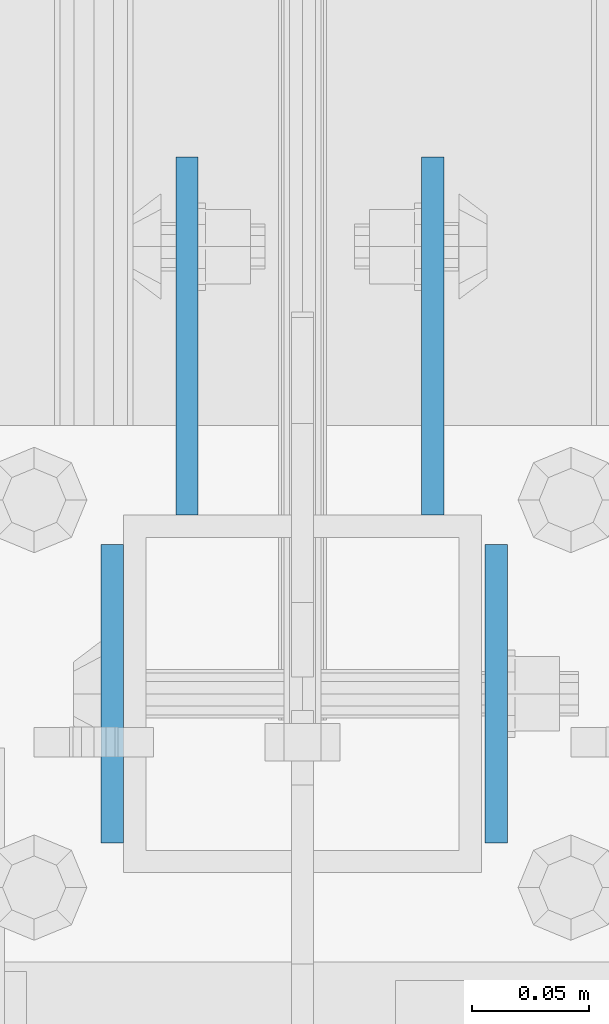
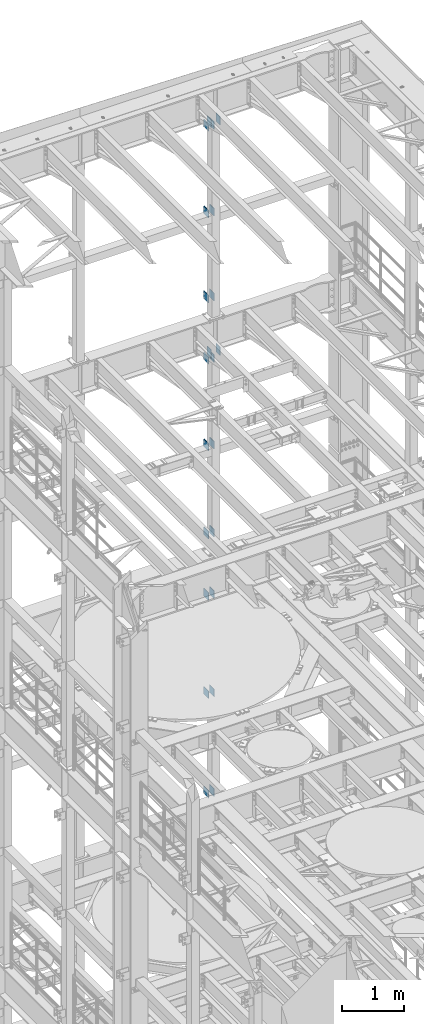
# One storey, part 1327 of 1876: 22 beams, 5 elements without a shape of their own.
"""IFC2X3 building model written with IfcOpenShell, lengths in millimetres."""

from ifc_helpers import new_model, si_unit, frame, origin_with_axes, place, context, subcontext, project, spatial, faceted_brep, material, type_object, element, aggregate, save


model = new_model("IFC2X3")

# Units and contexts
model_context = context("Model", 3, precision=1e-05, world=origin_with_axes())
body_context = subcontext(model_context, "Body", "Model", "MODEL_VIEW")
ifc_project = project(units=[si_unit("LENGTHUNIT", "METRE", prefix="MILLI"), si_unit("AREAUNIT", "SQUARE_METRE"), si_unit("VOLUMEUNIT", "CUBIC_METRE"), si_unit("MASSUNIT", "GRAM", prefix="KILO"), si_unit("TIMEUNIT", "SECOND"), si_unit("PLANEANGLEUNIT", "RADIAN"), si_unit("SOLIDANGLEUNIT", "STERADIAN"), si_unit("THERMODYNAMICTEMPERATUREUNIT", "DEGREE_CELSIUS"), si_unit("LUMINOUSINTENSITYUNIT", "LUMEN")], contexts=[model_context])

# Site, building, storey
site_placement = place(None, origin_with_axes())
site = spatial("IfcSite", under=ifc_project, at=site_placement, CompositionType="ELEMENT")
building_placement = place(site_placement, origin_with_axes())
building = spatial("IfcBuilding", under=site, at=building_placement, Name="Undefined", CompositionType="ELEMENT")
storey_placement = place(building_placement, origin_with_axes())
storey = spatial("IfcBuildingStorey", under=building, at=storey_placement, Name="Undefined", CompositionType="ELEMENT", Elevation=0.0)

# Assembly, beams
assembly_1_placement = place(storey_placement, origin_with_axes())
assembly_1 = element("IfcElementAssembly", 1, at=assembly_1_placement, inside=storey, Name="FRAME", AssemblyPlace="NOTDEFINED", PredefinedType="RIGID_FRAME")
ifc_material = material(Name="STEEL/A36")
beam_type_1 = type_object("IfcBeamType", PredefinedType="NOTDEFINED")
beam_1_placement = place(assembly_1_placement, frame((5030.7762944527, 13792.2, 21678.9), z_axis=(0.0, 0.0, -1.0), x_axis=(0.0, 1.0, 0.0)))
beam_1 = element("IfcBeam", 2, at=beam_1_placement, type_object=beam_type_1, material=ifc_material, Name="PLATE", context=body_context, shape_type="Brep", body=[
    faceted_brep([(0.0, 4.76249999999982, -76.1999999999998), (3.63797880709171e-12, 4.76249999999982, 76.1999969482422), (152.399993896484, 4.76250000000073, 76.1999969482422), (152.4, 4.76249999999982, -76.1999999999998), (3.63797880709171e-12, -4.76249999999982, 76.1999969482422), (152.399993896484, -4.76250000000073, 76.1999969482422), (0.0, -4.76249999999982, -76.1999999999998), (152.4, -4.76249999999982, -76.1999999999998)], [[[0, 1, 2, 3]], [[4, 5, 2, 1]], [[4, 6, 7, 5]], [[6, 0, 3, 7]], [[5, 7, 3, 2]], [[6, 4, 1, 0]]]),
])
beam_2_placement = place(assembly_1_placement, frame((5135.5512944527, 13792.2, 21678.9), z_axis=(0.0, 0.0, -1.0), x_axis=(0.0, 1.0, 0.0)))
beam_2 = element("IfcBeam", 3, at=beam_2_placement, type_object=beam_type_1, material=ifc_material, Name="PLATE", context=body_context, shape_type="Brep", body=[
    faceted_brep([(0.0, 4.76249999999982, -76.1999999999998), (3.63797880709171e-12, 4.76249999999982, 76.1999969482422), (152.399993896484, 4.76250000000073, 76.1999969482422), (152.4, 4.76249999999982, -76.1999999999998), (3.63797880709171e-12, -4.76249999999982, 76.1999969482422), (152.399993896484, -4.76250000000073, 76.1999969482422), (0.0, -4.76249999999982, -76.1999999999998), (152.4, -4.76249999999982, -76.1999999999998)], [[[0, 1, 2, 3]], [[4, 5, 2, 1]], [[4, 6, 7, 5]], [[6, 0, 3, 7]], [[5, 7, 3, 2]], [[6, 4, 1, 0]]]),
])
beam_3_placement = place(assembly_1_placement, frame((5030.7762944527, 13792.2, 19958.05), z_axis=(0.0, 0.0, -1.0), x_axis=(0.0, 1.0, 0.0)))
beam_3 = element("IfcBeam", 4, at=beam_3_placement, type_object=beam_type_1, material=ifc_material, Name="PLATE", context=body_context, shape_type="Brep", body=[
    faceted_brep([(0.0, 4.76249999999982, -76.1999999999998), (3.63797880709171e-12, 4.76249999999982, 76.1999969482422), (152.399993896484, 4.76250000000073, 76.1999969482422), (152.4, 4.76249999999982, -76.1999999999998), (3.63797880709171e-12, -4.76249999999982, 76.1999969482422), (152.399993896484, -4.76250000000073, 76.1999969482422), (0.0, -4.76249999999982, -76.1999999999998), (152.4, -4.76249999999982, -76.1999999999998)], [[[0, 1, 2, 3]], [[4, 5, 2, 1]], [[4, 6, 7, 5]], [[6, 0, 3, 7]], [[5, 7, 3, 2]], [[6, 4, 1, 0]]]),
])
beam_4_placement = place(assembly_1_placement, frame((5135.5512944527, 13792.2, 19958.05), z_axis=(0.0, 0.0, -1.0), x_axis=(0.0, 1.0, 0.0)))
beam_4 = element("IfcBeam", 5, at=beam_4_placement, type_object=beam_type_1, material=ifc_material, Name="PLATE", context=body_context, shape_type="Brep", body=[
    faceted_brep([(0.0, 4.76249999999982, -76.1999999999998), (3.63797880709171e-12, 4.76249999999982, 76.1999969482422), (152.399993896484, 4.76250000000073, 76.1999969482422), (152.4, 4.76249999999982, -76.1999999999998), (3.63797880709171e-12, -4.76249999999982, 76.1999969482422), (152.399993896484, -4.76250000000073, 76.1999969482422), (0.0, -4.76249999999982, -76.1999999999998), (152.4, -4.76249999999982, -76.1999999999998)], [[[0, 1, 2, 3]], [[4, 5, 2, 1]], [[4, 6, 7, 5]], [[6, 0, 3, 7]], [[5, 7, 3, 2]], [[6, 4, 1, 0]]]),
])
beam_5_placement = place(assembly_1_placement, frame((5030.7762944527, 13792.2, 18275.3), z_axis=(0.0, 0.0, -1.0), x_axis=(0.0, 1.0, 0.0)))
beam_5 = element("IfcBeam", 6, at=beam_5_placement, type_object=beam_type_1, material=ifc_material, Name="PLATE", context=body_context, shape_type="Brep", body=[
    faceted_brep([(0.0, 4.76249999999982, -76.1999999999998), (3.63797880709171e-12, 4.76249999999982, 76.1999969482422), (152.399993896484, 4.76250000000073, 76.1999969482422), (152.4, 4.76249999999982, -76.1999999999998), (3.63797880709171e-12, -4.76249999999982, 76.1999969482422), (152.399993896484, -4.76250000000073, 76.1999969482422), (0.0, -4.76249999999982, -76.1999999999998), (152.4, -4.76249999999982, -76.1999999999998)], [[[0, 1, 2, 3]], [[4, 5, 2, 1]], [[4, 6, 7, 5]], [[6, 0, 3, 7]], [[5, 7, 3, 2]], [[6, 4, 1, 0]]]),
])
beam_6_placement = place(assembly_1_placement, frame((5135.5512944527, 13792.2, 18275.3), z_axis=(0.0, 0.0, -1.0), x_axis=(0.0, 1.0, 0.0)))
beam_6 = element("IfcBeam", 7, at=beam_6_placement, type_object=beam_type_1, material=ifc_material, Name="PLATE", context=body_context, shape_type="Brep", body=[
    faceted_brep([(0.0, 4.76249999999982, -76.1999999999998), (3.63797880709171e-12, 4.76249999999982, 76.1999969482422), (152.399993896484, 4.76250000000073, 76.1999969482422), (152.4, 4.76249999999982, -76.1999999999998), (3.63797880709171e-12, -4.76249999999982, 76.1999969482422), (152.399993896484, -4.76250000000073, 76.1999969482422), (0.0, -4.76249999999982, -76.1999999999998), (152.4, -4.76249999999982, -76.1999999999998)], [[[0, 1, 2, 3]], [[4, 5, 2, 1]], [[4, 6, 7, 5]], [[6, 0, 3, 7]], [[5, 7, 3, 2]], [[6, 4, 1, 0]]]),
])
aggregate(assembly_1, [beam_1, beam_2, beam_3, beam_4, beam_5, beam_6])

assembly_2_placement = place(storey_placement, origin_with_axes())
assembly_2 = element("IfcElementAssembly", 8, at=assembly_2_placement, inside=storey, Name="FRAME", AssemblyPlace="NOTDEFINED", PredefinedType="RIGID_FRAME")
beam_7_placement = place(assembly_2_placement, frame((5030.7762944527, 13792.2, 17056.1), z_axis=(0.0, 0.0, -1.0), x_axis=(0.0, 1.0, 0.0)))
beam_7 = element("IfcBeam", 9, at=beam_7_placement, type_object=beam_type_1, material=ifc_material, Name="PLATE", context=body_context, shape_type="Brep", body=[
    faceted_brep([(0.0, 4.76249999999982, -76.1999999999998), (3.63797880709171e-12, 4.76249999999982, 76.1999969482422), (152.399993896484, 4.76250000000073, 76.1999969482422), (152.4, 4.76249999999982, -76.1999999999998), (3.63797880709171e-12, -4.76249999999982, 76.1999969482422), (152.399993896484, -4.76250000000073, 76.1999969482422), (0.0, -4.76249999999982, -76.1999999999998), (152.4, -4.76249999999982, -76.1999999999998)], [[[0, 1, 2, 3]], [[4, 5, 2, 1]], [[4, 6, 7, 5]], [[6, 0, 3, 7]], [[5, 7, 3, 2]], [[6, 4, 1, 0]]]),
])
beam_8_placement = place(assembly_2_placement, frame((5135.5512944527, 13792.2, 17056.1), z_axis=(0.0, 0.0, -1.0), x_axis=(0.0, 1.0, 0.0)))
beam_8 = element("IfcBeam", 10, at=beam_8_placement, type_object=beam_type_1, material=ifc_material, Name="PLATE", context=body_context, shape_type="Brep", body=[
    faceted_brep([(0.0, 4.76249999999982, -76.1999999999998), (3.63797880709171e-12, 4.76249999999982, 76.1999969482422), (152.399993896484, 4.76250000000073, 76.1999969482422), (152.4, 4.76249999999982, -76.1999999999998), (3.63797880709171e-12, -4.76249999999982, 76.1999969482422), (152.399993896484, -4.76250000000073, 76.1999969482422), (0.0, -4.76249999999982, -76.1999999999998), (152.4, -4.76249999999982, -76.1999999999998)], [[[0, 1, 2, 3]], [[4, 5, 2, 1]], [[4, 6, 7, 5]], [[6, 0, 3, 7]], [[5, 7, 3, 2]], [[6, 4, 1, 0]]]),
])
beam_9_placement = place(assembly_2_placement, frame((5030.7762944527, 13792.2, 15335.25), z_axis=(0.0, 0.0, -1.0), x_axis=(0.0, 1.0, 0.0)))
beam_9 = element("IfcBeam", 11, at=beam_9_placement, type_object=beam_type_1, material=ifc_material, Name="PLATE", context=body_context, shape_type="Brep", body=[
    faceted_brep([(0.0, 4.76249999999982, -76.1999999999998), (3.63797880709171e-12, 4.76249999999982, 76.1999969482422), (152.399993896484, 4.76250000000073, 76.1999969482422), (152.4, 4.76249999999982, -76.1999999999998), (3.63797880709171e-12, -4.76249999999982, 76.1999969482422), (152.399993896484, -4.76250000000073, 76.1999969482422), (0.0, -4.76249999999982, -76.1999999999998), (152.4, -4.76249999999982, -76.1999999999998)], [[[0, 1, 2, 3]], [[4, 5, 2, 1]], [[4, 6, 7, 5]], [[6, 0, 3, 7]], [[5, 7, 3, 2]], [[6, 4, 1, 0]]]),
])
beam_10_placement = place(assembly_2_placement, frame((5135.5512944527, 13792.2, 15335.25), z_axis=(0.0, 0.0, -1.0), x_axis=(0.0, 1.0, 0.0)))
beam_10 = element("IfcBeam", 12, at=beam_10_placement, type_object=beam_type_1, material=ifc_material, Name="PLATE", context=body_context, shape_type="Brep", body=[
    faceted_brep([(0.0, 4.76249999999982, -76.1999999999998), (3.63797880709171e-12, 4.76249999999982, 76.1999969482422), (152.399993896484, 4.76250000000073, 76.1999969482422), (152.4, 4.76249999999982, -76.1999999999998), (3.63797880709171e-12, -4.76249999999982, 76.1999969482422), (152.399993896484, -4.76250000000073, 76.1999969482422), (0.0, -4.76249999999982, -76.1999999999998), (152.4, -4.76249999999982, -76.1999999999998)], [[[0, 1, 2, 3]], [[4, 5, 2, 1]], [[4, 6, 7, 5]], [[6, 0, 3, 7]], [[5, 7, 3, 2]], [[6, 4, 1, 0]]]),
])
beam_11_placement = place(assembly_2_placement, frame((5030.7762944527, 13792.2, 13589.0), z_axis=(0.0, 0.0, -1.0), x_axis=(0.0, 1.0, 0.0)))
beam_11 = element("IfcBeam", 13, at=beam_11_placement, type_object=beam_type_1, material=ifc_material, Name="PLATE", context=body_context, shape_type="Brep", body=[
    faceted_brep([(0.0, 4.76249999999982, -76.1999999999998), (3.63797880709171e-12, 4.76249999999982, 76.1999969482422), (152.399993896484, 4.76250000000073, 76.1999969482422), (152.4, 4.76249999999982, -76.1999999999998), (3.63797880709171e-12, -4.76249999999982, 76.1999969482422), (152.399993896484, -4.76250000000073, 76.1999969482422), (0.0, -4.76249999999982, -76.1999999999998), (152.4, -4.76249999999982, -76.1999999999998)], [[[0, 1, 2, 3]], [[4, 5, 2, 1]], [[4, 6, 7, 5]], [[6, 0, 3, 7]], [[5, 7, 3, 2]], [[6, 4, 1, 0]]]),
])
beam_12_placement = place(assembly_2_placement, frame((5135.5512944527, 13792.2, 13589.0), z_axis=(0.0, 0.0, -1.0), x_axis=(0.0, 1.0, 0.0)))
beam_12 = element("IfcBeam", 14, at=beam_12_placement, type_object=beam_type_1, material=ifc_material, Name="PLATE", context=body_context, shape_type="Brep", body=[
    faceted_brep([(0.0, 4.76249999999982, -76.1999999999998), (3.63797880709171e-12, 4.76249999999982, 76.1999969482422), (152.399993896484, 4.76250000000073, 76.1999969482422), (152.4, 4.76249999999982, -76.1999999999998), (3.63797880709171e-12, -4.76249999999982, 76.1999969482422), (152.399993896484, -4.76250000000073, 76.1999969482422), (0.0, -4.76249999999982, -76.1999999999998), (152.4, -4.76249999999982, -76.1999999999998)], [[[0, 1, 2, 3]], [[4, 5, 2, 1]], [[4, 6, 7, 5]], [[6, 0, 3, 7]], [[5, 7, 3, 2]], [[6, 4, 1, 0]]]),
])
aggregate(assembly_2, [beam_7, beam_8, beam_9, beam_10, beam_11, beam_12])

assembly_3_placement = place(storey_placement, origin_with_axes())
assembly_3 = element("IfcElementAssembly", 15, at=assembly_3_placement, inside=storey, Name="FRAME", AssemblyPlace="NOTDEFINED", PredefinedType="RIGID_FRAME")
beam_13_placement = place(assembly_3_placement, frame((5030.7762944527, 13792.2, 12369.8), z_axis=(0.0, 0.0, -1.0), x_axis=(0.0, 1.0, 0.0)))
beam_13 = element("IfcBeam", 16, at=beam_13_placement, type_object=beam_type_1, material=ifc_material, Name="PLATE", context=body_context, shape_type="Brep", body=[
    faceted_brep([(0.0, 4.76249999999982, -76.1999999999998), (3.63797880709171e-12, 4.76249999999982, 76.1999969482422), (152.399993896484, 4.76250000000073, 76.1999969482422), (152.4, 4.76249999999982, -76.1999999999998), (3.63797880709171e-12, -4.76249999999982, 76.1999969482422), (152.399993896484, -4.76250000000073, 76.1999969482422), (0.0, -4.76249999999982, -76.1999999999998), (152.4, -4.76249999999982, -76.1999999999998)], [[[0, 1, 2, 3]], [[4, 5, 2, 1]], [[4, 6, 7, 5]], [[6, 0, 3, 7]], [[5, 7, 3, 2]], [[6, 4, 1, 0]]]),
])
beam_14_placement = place(assembly_3_placement, frame((5135.5512944527, 13792.2, 12369.8), z_axis=(0.0, 0.0, -1.0), x_axis=(0.0, 1.0, 0.0)))
beam_14 = element("IfcBeam", 17, at=beam_14_placement, type_object=beam_type_1, material=ifc_material, Name="PLATE", context=body_context, shape_type="Brep", body=[
    faceted_brep([(0.0, 4.76249999999982, -76.1999999999998), (3.63797880709171e-12, 4.76249999999982, 76.1999969482422), (152.399993896484, 4.76250000000073, 76.1999969482422), (152.4, 4.76249999999982, -76.1999999999998), (3.63797880709171e-12, -4.76249999999982, 76.1999969482422), (152.399993896484, -4.76250000000073, 76.1999969482422), (0.0, -4.76249999999982, -76.1999999999998), (152.4, -4.76249999999982, -76.1999999999998)], [[[0, 1, 2, 3]], [[4, 5, 2, 1]], [[4, 6, 7, 5]], [[6, 0, 3, 7]], [[5, 7, 3, 2]], [[6, 4, 1, 0]]]),
])
beam_15_placement = place(assembly_3_placement, frame((5030.7762944527, 13792.2, 10420.35), z_axis=(0.0, 0.0, -1.0), x_axis=(0.0, 1.0, 0.0)))
beam_15 = element("IfcBeam", 18, at=beam_15_placement, type_object=beam_type_1, material=ifc_material, Name="PLATE", context=body_context, shape_type="Brep", body=[
    faceted_brep([(0.0, 4.76249999999982, -76.1999999999998), (3.63797880709171e-12, 4.76249999999982, 76.1999969482422), (152.399993896484, 4.76250000000073, 76.1999969482422), (152.4, 4.76249999999982, -76.1999999999998), (3.63797880709171e-12, -4.76249999999982, 76.1999969482422), (152.399993896484, -4.76250000000073, 76.1999969482422), (0.0, -4.76249999999982, -76.1999999999998), (152.4, -4.76249999999982, -76.1999999999998)], [[[0, 1, 2, 3]], [[4, 5, 2, 1]], [[4, 6, 7, 5]], [[6, 0, 3, 7]], [[5, 7, 3, 2]], [[6, 4, 1, 0]]]),
])
beam_16_placement = place(assembly_3_placement, frame((5135.5512944527, 13792.2, 10420.35), z_axis=(0.0, 0.0, -1.0), x_axis=(0.0, 1.0, 0.0)))
beam_16 = element("IfcBeam", 19, at=beam_16_placement, type_object=beam_type_1, material=ifc_material, Name="PLATE", context=body_context, shape_type="Brep", body=[
    faceted_brep([(0.0, 4.76249999999982, -76.1999999999998), (3.63797880709171e-12, 4.76249999999982, 76.1999969482422), (152.399993896484, 4.76250000000073, 76.1999969482422), (152.4, 4.76249999999982, -76.1999999999998), (3.63797880709171e-12, -4.76249999999982, 76.1999969482422), (152.399993896484, -4.76250000000073, 76.1999969482422), (0.0, -4.76249999999982, -76.1999999999998), (152.4, -4.76249999999982, -76.1999999999998)], [[[0, 1, 2, 3]], [[4, 5, 2, 1]], [[4, 6, 7, 5]], [[6, 0, 3, 7]], [[5, 7, 3, 2]], [[6, 4, 1, 0]]]),
])
beam_17_placement = place(assembly_3_placement, frame((5030.7762944527, 13792.2, 8445.5), z_axis=(0.0, 0.0, -1.0), x_axis=(0.0, 1.0, 0.0)))
beam_17 = element("IfcBeam", 20, at=beam_17_placement, type_object=beam_type_1, material=ifc_material, Name="PLATE", context=body_context, shape_type="Brep", body=[
    faceted_brep([(0.0, 4.76249999999982, -76.1999999999998), (3.63797880709171e-12, 4.76249999999982, 76.1999969482422), (152.399993896484, 4.76250000000073, 76.1999969482422), (152.4, 4.76249999999982, -76.1999999999998), (3.63797880709171e-12, -4.76249999999982, 76.1999969482422), (152.399993896484, -4.76250000000073, 76.1999969482422), (0.0, -4.76249999999982, -76.1999999999998), (152.4, -4.76249999999982, -76.1999999999998)], [[[0, 1, 2, 3]], [[4, 5, 2, 1]], [[4, 6, 7, 5]], [[6, 0, 3, 7]], [[5, 7, 3, 2]], [[6, 4, 1, 0]]]),
])
beam_18_placement = place(assembly_3_placement, frame((5135.5512944527, 13792.2, 8445.5), z_axis=(0.0, 0.0, -1.0), x_axis=(0.0, 1.0, 0.0)))
beam_18 = element("IfcBeam", 21, at=beam_18_placement, type_object=beam_type_1, material=ifc_material, Name="PLATE", context=body_context, shape_type="Brep", body=[
    faceted_brep([(0.0, 4.76249999999982, -76.1999999999998), (3.63797880709171e-12, 4.76249999999982, 76.1999969482422), (152.399993896484, 4.76250000000073, 76.1999969482422), (152.4, 4.76249999999982, -76.1999999999998), (3.63797880709171e-12, -4.76249999999982, 76.1999969482422), (152.399993896484, -4.76250000000073, 76.1999969482422), (0.0, -4.76249999999982, -76.1999999999998), (152.4, -4.76249999999982, -76.1999999999998)], [[[0, 1, 2, 3]], [[4, 5, 2, 1]], [[4, 6, 7, 5]], [[6, 0, 3, 7]], [[5, 7, 3, 2]], [[6, 4, 1, 0]]]),
])
aggregate(assembly_3, [beam_13, beam_14, beam_15, beam_16, beam_17, beam_18])

assembly_4_placement = place(storey_placement, origin_with_axes())
assembly_4 = element("IfcElementAssembly", 22, at=assembly_4_placement, inside=storey, Name="BEAM", AssemblyPlace="NOTDEFINED", PredefinedType="RIGID_FRAME")
beam_type_2 = type_object("IfcBeamType", PredefinedType="NOTDEFINED")
beam_19_placement = place(assembly_4_placement, frame((5162.55, 13779.5, 17278.35), z_axis=(0.0, 0.0, -1.0), x_axis=(0.0, -1.0, 0.0)))
beam_19 = element("IfcBeam", 23, at=beam_19_placement, type_object=beam_type_2, material=ifc_material, Name="PLATE", context=body_context, shape_type="Brep", body=[
    faceted_brep([(0.0, 4.76249999999982, -82.5499999999993), (0.0, 4.76249999999982, 82.5499999999993), (127.0, 4.76249999999982, 82.5499999999993), (127.0, 4.76249999999982, -82.5499999999993), (0.0, -4.76249999999982, 82.5499999999993), (127.0, -4.76249999999982, 82.5499999999993), (0.0, -4.76249999999982, -82.5499999999993), (127.0, -4.76249999999982, -82.5499999999993)], [[[0, 1, 2, 3]], [[1, 4, 5, 2]], [[4, 6, 7, 5]], [[6, 0, 3, 7]], [[5, 7, 3, 2]], [[6, 4, 1, 0]]]),
])
beam_20_placement = place(assembly_4_placement, frame((4999.0375, 13779.5, 17278.35), z_axis=(0.0, 0.0, -1.0), x_axis=(0.0, -1.0, 0.0)))
beam_20 = element("IfcBeam", 24, at=beam_20_placement, type_object=beam_type_2, material=ifc_material, Name="PLATE", context=body_context, shape_type="Brep", body=[
    faceted_brep([(0.0, 4.76249999999982, -82.5499999999993), (0.0, 4.76249999999982, 82.5499999999993), (127.0, 4.76249999999982, 82.5499999999993), (127.0, 4.76249999999982, -82.5499999999993), (0.0, -4.76249999999982, 82.5499999999993), (127.0, -4.76249999999982, 82.5499999999993), (0.0, -4.76249999999982, -82.5499999999993), (127.0, -4.76249999999982, -82.5499999999993)], [[[0, 1, 2, 3]], [[1, 4, 5, 2]], [[4, 6, 7, 5]], [[6, 0, 3, 7]], [[5, 7, 3, 2]], [[6, 4, 1, 0]]]),
])
aggregate(assembly_4, [beam_19, beam_20])

assembly_5_placement = place(storey_placement, origin_with_axes())
assembly_5 = element("IfcElementAssembly", 25, at=assembly_5_placement, inside=storey, Name="BEAM", AssemblyPlace="NOTDEFINED", PredefinedType="RIGID_FRAME")
beam_21_placement = place(assembly_5_placement, frame((5162.55, 13779.5, 21850.35), z_axis=(0.0, 0.0, -1.0), x_axis=(0.0, -1.0, 0.0)))
beam_21 = element("IfcBeam", 26, at=beam_21_placement, type_object=beam_type_2, material=ifc_material, Name="PLATE", context=body_context, shape_type="Brep", body=[
    faceted_brep([(0.0, 4.76249999999982, -82.5499999999993), (0.0, 4.76249999999982, 82.5499999999993), (127.0, 4.76249999999982, 82.5499999999993), (127.0, 4.76249999999982, -82.5499999999993), (0.0, -4.76249999999982, 82.5499999999993), (127.0, -4.76249999999982, 82.5499999999993), (0.0, -4.76249999999982, -82.5499999999993), (127.0, -4.76249999999982, -82.5499999999993)], [[[0, 1, 2, 3]], [[1, 4, 5, 2]], [[4, 6, 7, 5]], [[6, 0, 3, 7]], [[5, 7, 3, 2]], [[6, 4, 1, 0]]]),
])
beam_22_placement = place(assembly_5_placement, frame((4999.0375, 13779.5, 21850.35), z_axis=(0.0, 0.0, -1.0), x_axis=(0.0, -1.0, 0.0)))
beam_22 = element("IfcBeam", 27, at=beam_22_placement, type_object=beam_type_2, material=ifc_material, Name="PLATE", context=body_context, shape_type="Brep", body=[
    faceted_brep([(0.0, 4.76249999999982, -82.5499999999993), (0.0, 4.76249999999982, 82.5499999999993), (127.0, 4.76249999999982, 82.5499999999993), (127.0, 4.76249999999982, -82.5499999999993), (0.0, -4.76249999999982, 82.5499999999993), (127.0, -4.76249999999982, 82.5499999999993), (0.0, -4.76249999999982, -82.5499999999993), (127.0, -4.76249999999982, -82.5499999999993)], [[[0, 1, 2, 3]], [[1, 4, 5, 2]], [[4, 6, 7, 5]], [[6, 0, 3, 7]], [[5, 7, 3, 2]], [[6, 4, 1, 0]]]),
])
aggregate(assembly_5, [beam_21, beam_22])

save(model, "model.ifc")
